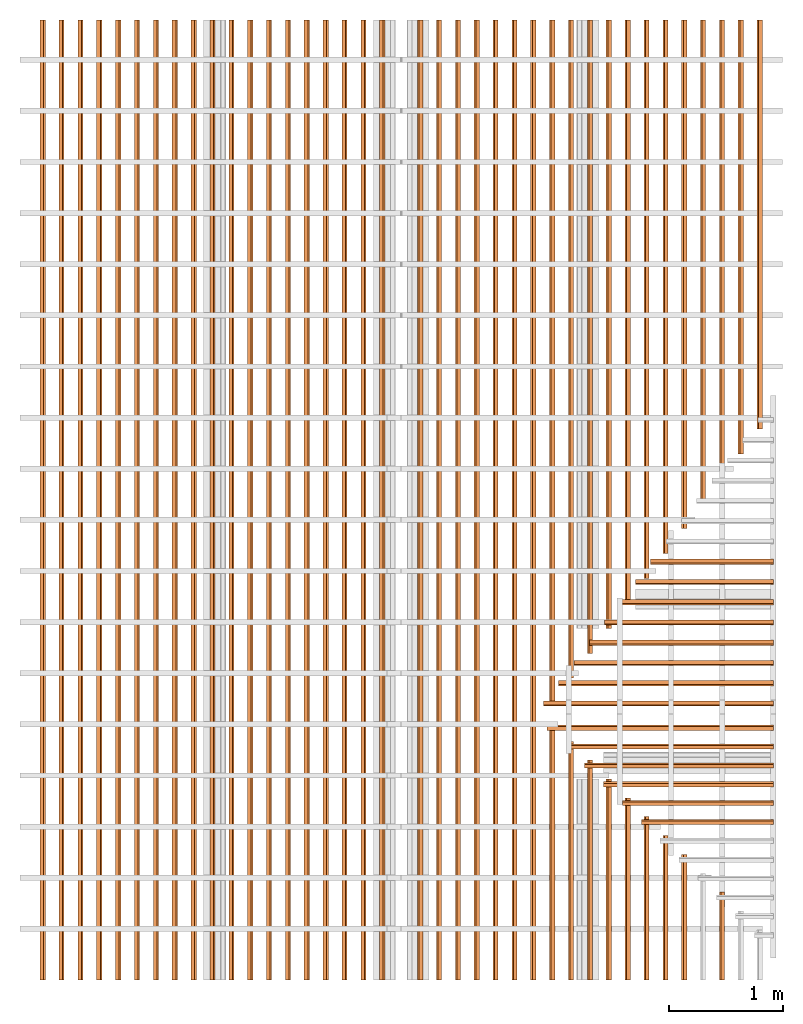
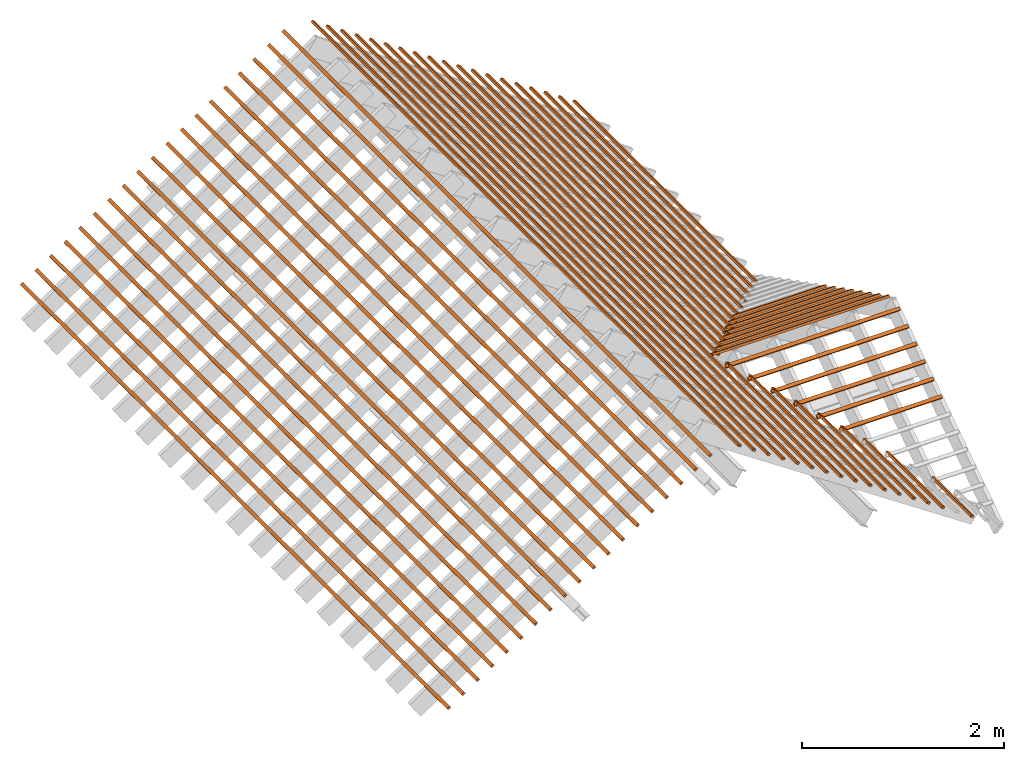
# One storey, part 2 of 3: 61 proxies, 5 elements without a shape of their own.
"""IFC4 building model written with IfcOpenShell, lengths in metres."""

from ifc_helpers import new_model, entity, si_unit, converted_unit, frame, frame_2d, origin_with_axes, origin_2d_with_axis, place, context, subcontext, project, library, spatial, rectangle, extrude, material, material_profile, profile_set, profile_usage, type_object, element, aggregate, save


model = new_model("IFC4")

# Units and contexts
model_context = context("Model", 3, precision=1e-05, world=origin_with_axes())
plan_context = context("Plan", 2, precision=1e-05, world=origin_2d_with_axis())
body_context = subcontext(model_context, "Body", "Model", "MODEL_VIEW")
ifc_project = project(units=[si_unit("LENGTHUNIT", "METRE"), converted_unit("PLANEANGLEUNIT", "degree", entity("IfcReal", 0.0174532925199433), si_unit("PLANEANGLEUNIT", "RADIAN"), dimensions=[0, 0, 0, 0, 0, 0, 0]), si_unit("AREAUNIT", "SQUARE_METRE"), si_unit("VOLUMEUNIT", "CUBIC_METRE")], contexts=[model_context, plan_context])
project_library_1 = library(declared=ifc_project)
project_library_2 = library(declared=ifc_project)
project_library_3 = library(declared=ifc_project)

# Site, building, storey
site_placement = place(None, frame((-0.0250487327575684, 0.0, 0.0), z_axis=(0.0, 0.0, 1.0), x_axis=(1.0, 0.0, 0.0)))
site = spatial("IfcSite", under=ifc_project, at=site_placement)
building_placement = place(site_placement, origin_with_axes())
building = spatial("IfcBuilding", under=site, at=building_placement, Name="Building")
storey_placement = place(building_placement, frame((0.0250487327575684, 0.0, 0.0), z_axis=(0.0, 0.0, 1.0), x_axis=(1.0, 0.0, 0.0)))
storey = spatial("IfcBuildingStorey", under=building, at=storey_placement, Name="Roof framing", CompositionType="ELEMENT", Elevation=0.0)

# Assemblies, proxies
assembly_1_placement = place(storey_placement, origin_with_axes())
assembly_1 = element("IfcElementAssembly", 1, at=assembly_1_placement, inside=storey, Name="battens")
assembly_2_placement = place(assembly_1_placement, frame((1.27500009536743, -6.61744490042422e-24, 2.40000009536743), z_axis=(0.557621447781006, -6.78052809385821e-09, 0.830095368602075), x_axis=(1.21597333116231e-08, 1.0, -6.86638795477696e-25)))
assembly_2 = element("IfcElementAssembly", 2, at=assembly_2_placement, Name="battens")
ifc_material = material(Name="Timber")
ifc_material_profile = material_profile(ifc_material, rectangle(XDim=0.038, YDim=0.026, at=frame_2d((0.0, 0.083), x_axis=(1.0, 0.0))))
ifc_profile_set = profile_set([ifc_material_profile])
ifc_profile_usage_1 = profile_usage(ifc_profile_set)
building_element_proxy_type = type_object("IfcBuildingElementProxyType", Name="batten", PredefinedType="NOTDEFINED", material=ifc_profile_set)
proxy_1_placement = place(assembly_2_placement, frame((0.773057153131958, 0.6, 0.0), z_axis=(-1.0, 0.0, 0.0), x_axis=(0.0, -1.0, 0.0)))
proxy_1 = element("IfcBuildingElementProxy", 3, at=proxy_1_placement, type_object=building_element_proxy_type, material=ifc_profile_usage_1, Name="batten", context=body_context, shape_type="SweptSolid", body=[
    extrude(rectangle(XDim=0.038, YDim=0.026, at=frame_2d((0.0, 0.083), x_axis=(1.0, 0.0))), origin_with_axes(), (0.0, 0.0, 1.0), 0.77305719295508),
])
ifc_profile_usage_2 = profile_usage(ifc_profile_set)
proxy_2_placement = place(assembly_2_placement, frame((1.10509527265061, 1.0, 0.0), z_axis=(-1.0, 0.0, 0.0), x_axis=(0.0, -1.0, 0.0)))
proxy_2 = element("IfcBuildingElementProxy", 4, at=proxy_2_placement, type_object=building_element_proxy_type, material=ifc_profile_usage_2, Name="batten", context=body_context, shape_type="SweptSolid", body=[
    extrude(rectangle(XDim=0.038, YDim=0.026, at=frame_2d((0.0, 0.083), x_axis=(1.0, 0.0))), origin_with_axes(), (0.0, 0.0, 1.0), 1.10509531247373),
])
ifc_profile_usage_3 = profile_usage(ifc_profile_set)
proxy_3_placement = place(assembly_2_placement, frame((1.27111433240993, 1.2, 0.0), z_axis=(-1.0, 0.0, 0.0), x_axis=(0.0, -1.0, 0.0)))
proxy_3 = element("IfcBuildingElementProxy", 5, at=proxy_3_placement, type_object=building_element_proxy_type, material=ifc_profile_usage_3, Name="batten", context=body_context, shape_type="SweptSolid", body=[
    extrude(rectangle(XDim=0.038, YDim=0.026, at=frame_2d((0.0, 0.083), x_axis=(1.0, 0.0))), origin_with_axes(), (0.0, 0.0, 1.0), 1.27111437223306),
])
ifc_profile_usage_4 = profile_usage(ifc_profile_set)
proxy_4_placement = place(assembly_2_placement, frame((1.43713339216926, 1.4, 0.0), z_axis=(-1.0, 0.0, 0.0), x_axis=(0.0, -1.0, 0.0)))
proxy_4 = element("IfcBuildingElementProxy", 6, at=proxy_4_placement, type_object=building_element_proxy_type, material=ifc_profile_usage_4, Name="batten", context=body_context, shape_type="SweptSolid", body=[
    extrude(rectangle(XDim=0.038, YDim=0.026, at=frame_2d((0.0, 0.083), x_axis=(1.0, 0.0))), origin_with_axes(), (0.0, 0.0, 1.0), 1.43713343199238),
])
ifc_profile_usage_5 = profile_usage(ifc_profile_set)
proxy_5_placement = place(assembly_2_placement, frame((1.60315245192858, 1.6, 0.0), z_axis=(-1.0, 0.0, 0.0), x_axis=(0.0, -1.0, 0.0)))
proxy_5 = element("IfcBuildingElementProxy", 7, at=proxy_5_placement, type_object=building_element_proxy_type, material=ifc_profile_usage_5, Name="batten", context=body_context, shape_type="SweptSolid", body=[
    extrude(rectangle(XDim=0.038, YDim=0.026, at=frame_2d((0.0, 0.083), x_axis=(1.0, 0.0))), origin_with_axes(), (0.0, 0.0, 1.0), 1.60315249175171),
])
ifc_profile_usage_6 = profile_usage(ifc_profile_set)
proxy_6_placement = place(assembly_2_placement, frame((1.76917151168791, 1.8, 0.0), z_axis=(-1.0, 0.0, 0.0), x_axis=(0.0, -1.0, 0.0)))
proxy_6 = element("IfcBuildingElementProxy", 8, at=proxy_6_placement, type_object=building_element_proxy_type, material=ifc_profile_usage_6, Name="batten", context=body_context, shape_type="SweptSolid", body=[
    extrude(rectangle(XDim=0.038, YDim=0.026, at=frame_2d((0.0, 0.083), x_axis=(1.0, 0.0))), origin_with_axes(), (0.0, 0.0, 1.0), 1.76917155151103),
])
ifc_profile_usage_7 = profile_usage(ifc_profile_set)
proxy_7_placement = place(assembly_2_placement, frame((1.93519057144723, 2.0, 0.0), z_axis=(-1.0, -1.1474043106238e-16, 0.0), x_axis=(1.1474043106238e-16, -1.0, 0.0)))
proxy_7 = element("IfcBuildingElementProxy", 9, at=proxy_7_placement, type_object=building_element_proxy_type, material=ifc_profile_usage_7, Name="batten", context=body_context, shape_type="SweptSolid", body=[
    extrude(rectangle(XDim=0.038, YDim=0.026, at=frame_2d((0.0, 0.083), x_axis=(1.0, 0.0))), origin_with_axes(), (0.0, 0.0, 1.0), 1.93519061127036),
])
ifc_profile_usage_8 = profile_usage(ifc_profile_set)
proxy_8_placement = place(assembly_2_placement, frame((2.10120963120656, 2.2, 0.0), z_axis=(-1.0, 2.11349307959562e-16, 0.0), x_axis=(-2.11349307959562e-16, -1.0, 0.0)))
proxy_8 = element("IfcBuildingElementProxy", 10, at=proxy_8_placement, type_object=building_element_proxy_type, material=ifc_profile_usage_8, Name="batten", context=body_context, shape_type="SweptSolid", body=[
    extrude(rectangle(XDim=0.038, YDim=0.026, at=frame_2d((0.0, 0.083), x_axis=(1.0, 0.0))), origin_with_axes(), (0.0, 0.0, 1.0), 2.10120967102968),
])
ifc_profile_usage_9 = profile_usage(ifc_profile_set)
proxy_9_placement = place(assembly_2_placement, frame((2.26722869096588, 2.4, 0.0), z_axis=(-1.0, 1.95873139670172e-16, 0.0), x_axis=(-1.95873139670172e-16, -1.0, 0.0)))
proxy_9 = element("IfcBuildingElementProxy", 11, at=proxy_9_placement, type_object=building_element_proxy_type, material=ifc_profile_usage_9, Name="batten", context=body_context, shape_type="SweptSolid", body=[
    extrude(rectangle(XDim=0.038, YDim=0.026, at=frame_2d((0.0, 0.083), x_axis=(1.0, 0.0))), origin_with_axes(), (0.0, 0.0, 1.0), 2.26722873078901),
])
ifc_profile_usage_10 = profile_usage(ifc_profile_set)
proxy_10_placement = place(assembly_2_placement, frame((8.44999980926514, 2.6, 0.0), z_axis=(-1.0, 0.0, 0.0), x_axis=(0.0, -1.0, 0.0)))
proxy_10 = element("IfcBuildingElementProxy", 12, at=proxy_10_placement, type_object=building_element_proxy_type, material=ifc_profile_usage_10, Name="batten", context=body_context, shape_type="SweptSolid", body=[
    extrude(rectangle(XDim=0.038, YDim=0.026, at=frame_2d((0.0, 0.083), x_axis=(1.0, 0.0))), origin_with_axes(), (0.0, 0.0, 1.0), 8.44999984908826),
])
ifc_profile_usage_11 = profile_usage(ifc_profile_set)
proxy_11_placement = place(assembly_2_placement, frame((8.44999980926514, 2.4, 0.0), z_axis=(-1.0, 0.0, 0.0), x_axis=(0.0, -1.0, 0.0)))
proxy_11 = element("IfcBuildingElementProxy", 13, at=proxy_11_placement, type_object=building_element_proxy_type, material=ifc_profile_usage_11, Name="batten", context=body_context, shape_type="SweptSolid", body=[
    extrude(rectangle(XDim=0.038, YDim=0.026, at=frame_2d((0.0, 0.083), x_axis=(1.0, 0.0))), origin_with_axes(), (0.0, 0.0, 1.0), 6.01336081066731),
])
ifc_profile_usage_12 = profile_usage(ifc_profile_set)
proxy_12_placement = place(assembly_2_placement, frame((8.44999980926514, 2.8, 0.0), z_axis=(-1.0, 0.0, 0.0), x_axis=(0.0, -1.0, 0.0)))
proxy_12 = element("IfcBuildingElementProxy", 14, at=proxy_12_placement, type_object=building_element_proxy_type, material=ifc_profile_usage_12, Name="batten", context=body_context, shape_type="SweptSolid", body=[
    extrude(rectangle(XDim=0.038, YDim=0.026, at=frame_2d((0.0, 0.083), x_axis=(1.0, 0.0))), origin_with_axes(), (0.0, 0.0, 1.0), 8.44999984908826),
])
ifc_profile_usage_13 = profile_usage(ifc_profile_set)
proxy_13_placement = place(assembly_2_placement, frame((8.44999980926514, 2.2, 0.0), z_axis=(-1.0, 0.0, 0.0), x_axis=(0.0, -1.0, 0.0)))
proxy_13 = element("IfcBuildingElementProxy", 15, at=proxy_13_placement, type_object=building_element_proxy_type, material=ifc_profile_usage_13, Name="batten", context=body_context, shape_type="SweptSolid", body=[
    extrude(rectangle(XDim=0.038, YDim=0.026, at=frame_2d((0.0, 0.083), x_axis=(1.0, 0.0))), origin_with_axes(), (0.0, 0.0, 1.0), 5.79391408130251),
])
ifc_profile_usage_14 = profile_usage(ifc_profile_set)
proxy_14_placement = place(assembly_2_placement, frame((8.44999980926514, 3.0, 0.0), z_axis=(-1.0, 0.0, 0.0), x_axis=(0.0, -1.0, 0.0)))
proxy_14 = element("IfcBuildingElementProxy", 16, at=proxy_14_placement, type_object=building_element_proxy_type, material=ifc_profile_usage_14, Name="batten", context=body_context, shape_type="SweptSolid", body=[
    extrude(rectangle(XDim=0.038, YDim=0.026, at=frame_2d((0.0, 0.083), x_axis=(1.0, 0.0))), origin_with_axes(), (0.0, 0.0, 1.0), 8.44999984908826),
])
ifc_profile_usage_15 = profile_usage(ifc_profile_set)
proxy_15_placement = place(assembly_2_placement, frame((8.44999980926514, 2.0, 0.0), z_axis=(-1.0, 0.0, 0.0), x_axis=(0.0, -1.0, 0.0)))
proxy_15 = element("IfcBuildingElementProxy", 17, at=proxy_15_placement, type_object=building_element_proxy_type, material=ifc_profile_usage_15, Name="batten", context=body_context, shape_type="SweptSolid", body=[
    extrude(rectangle(XDim=0.038, YDim=0.026, at=frame_2d((0.0, 0.083), x_axis=(1.0, 0.0))), origin_with_axes(), (0.0, 0.0, 1.0), 5.57446735193771),
])
ifc_profile_usage_16 = profile_usage(ifc_profile_set)
proxy_16_placement = place(assembly_2_placement, frame((8.44999980926514, 3.2, 0.0), z_axis=(-1.0, 0.0, 0.0), x_axis=(0.0, -1.0, 0.0)))
proxy_16 = element("IfcBuildingElementProxy", 18, at=proxy_16_placement, type_object=building_element_proxy_type, material=ifc_profile_usage_16, Name="batten", context=body_context, shape_type="SweptSolid", body=[
    extrude(rectangle(XDim=0.038, YDim=0.026, at=frame_2d((0.0, 0.083), x_axis=(1.0, 0.0))), origin_with_axes(), (0.0, 0.0, 1.0), 8.44999984908826),
])
ifc_profile_usage_17 = profile_usage(ifc_profile_set)
proxy_17_placement = place(assembly_2_placement, frame((8.44999980926514, 1.8, 0.0), z_axis=(-1.0, 0.0, 0.0), x_axis=(0.0, -1.0, 0.0)))
proxy_17 = element("IfcBuildingElementProxy", 19, at=proxy_17_placement, type_object=building_element_proxy_type, material=ifc_profile_usage_17, Name="batten", context=body_context, shape_type="SweptSolid", body=[
    extrude(rectangle(XDim=0.038, YDim=0.026, at=frame_2d((0.0, 0.083), x_axis=(1.0, 0.0))), origin_with_axes(), (0.0, 0.0, 1.0), 5.35502062257291),
])
ifc_profile_usage_18 = profile_usage(ifc_profile_set)
proxy_18_placement = place(assembly_2_placement, frame((8.44999980926514, 3.4, 0.0), z_axis=(-1.0, 0.0, 0.0), x_axis=(0.0, -1.0, 0.0)))
proxy_18 = element("IfcBuildingElementProxy", 20, at=proxy_18_placement, type_object=building_element_proxy_type, material=ifc_profile_usage_18, Name="batten", context=body_context, shape_type="SweptSolid", body=[
    extrude(rectangle(XDim=0.038, YDim=0.026, at=frame_2d((0.0, 0.083), x_axis=(1.0, 0.0))), origin_with_axes(), (0.0, 0.0, 1.0), 8.44999984908826),
])
ifc_profile_usage_19 = profile_usage(ifc_profile_set)
proxy_19_placement = place(assembly_2_placement, frame((8.44999980926514, 1.6, 0.0), z_axis=(-1.0, 0.0, 0.0), x_axis=(0.0, -1.0, 0.0)))
proxy_19 = element("IfcBuildingElementProxy", 21, at=proxy_19_placement, type_object=building_element_proxy_type, material=ifc_profile_usage_19, Name="batten", context=body_context, shape_type="SweptSolid", body=[
    extrude(rectangle(XDim=0.038, YDim=0.026, at=frame_2d((0.0, 0.083), x_axis=(1.0, 0.0))), origin_with_axes(), (0.0, 0.0, 1.0), 5.13557389320811),
])
ifc_profile_usage_20 = profile_usage(ifc_profile_set)
proxy_20_placement = place(assembly_2_placement, frame((8.44999980926514, 3.6, 0.0), z_axis=(-1.0, 0.0, 0.0), x_axis=(0.0, -1.0, 0.0)))
proxy_20 = element("IfcBuildingElementProxy", 22, at=proxy_20_placement, type_object=building_element_proxy_type, material=ifc_profile_usage_20, Name="batten", context=body_context, shape_type="SweptSolid", body=[
    extrude(rectangle(XDim=0.038, YDim=0.026, at=frame_2d((0.0, 0.083), x_axis=(1.0, 0.0))), origin_with_axes(), (0.0, 0.0, 1.0), 8.44999984908826),
])
ifc_profile_usage_21 = profile_usage(ifc_profile_set)
proxy_21_placement = place(assembly_2_placement, frame((8.44999980926514, 1.4, 0.0), z_axis=(-1.0, 0.0, 0.0), x_axis=(0.0, -1.0, 0.0)))
proxy_21 = element("IfcBuildingElementProxy", 23, at=proxy_21_placement, type_object=building_element_proxy_type, material=ifc_profile_usage_21, Name="batten", context=body_context, shape_type="SweptSolid", body=[
    extrude(rectangle(XDim=0.038, YDim=0.026, at=frame_2d((0.0, 0.083), x_axis=(1.0, 0.0))), origin_with_axes(), (0.0, 0.0, 1.0), 4.91612716384331),
])
ifc_profile_usage_22 = profile_usage(ifc_profile_set)
proxy_22_placement = place(assembly_2_placement, frame((8.44999980926514, 3.8, 0.0), z_axis=(-1.0, 0.0, 0.0), x_axis=(0.0, -1.0, 0.0)))
proxy_22 = element("IfcBuildingElementProxy", 24, at=proxy_22_placement, type_object=building_element_proxy_type, material=ifc_profile_usage_22, Name="batten", context=body_context, shape_type="SweptSolid", body=[
    extrude(rectangle(XDim=0.038, YDim=0.026, at=frame_2d((0.0, 0.083), x_axis=(1.0, 0.0))), origin_with_axes(), (0.0, 0.0, 1.0), 8.44999984908826),
])
ifc_profile_usage_23 = profile_usage(ifc_profile_set)
proxy_23_placement = place(assembly_2_placement, frame((8.44999980926514, 1.2, 0.0), z_axis=(-1.0, 4.72769242069342e-17, 0.0), x_axis=(-4.72769242069342e-17, -1.0, 0.0)))
proxy_23 = element("IfcBuildingElementProxy", 25, at=proxy_23_placement, type_object=building_element_proxy_type, material=ifc_profile_usage_23, Name="batten", context=body_context, shape_type="SweptSolid", body=[
    extrude(rectangle(XDim=0.038, YDim=0.026, at=frame_2d((0.0, 0.083), x_axis=(1.0, 0.0))), origin_with_axes(), (0.0, 0.0, 1.0), 4.69668043447851),
])
ifc_profile_usage_24 = profile_usage(ifc_profile_set)
proxy_24_placement = place(assembly_2_placement, frame((8.44999980926514, 1.0, 0.0), z_axis=(-1.0, 0.0, 0.0), x_axis=(0.0, -1.0, 0.0)))
proxy_24 = element("IfcBuildingElementProxy", 26, at=proxy_24_placement, type_object=building_element_proxy_type, material=ifc_profile_usage_24, Name="batten", context=body_context, shape_type="SweptSolid", body=[
    extrude(rectangle(XDim=0.038, YDim=0.026, at=frame_2d((0.0, 0.083), x_axis=(1.0, 0.0))), origin_with_axes(), (0.0, 0.0, 1.0), 4.47723370511371),
])
ifc_profile_usage_25 = profile_usage(ifc_profile_set)
proxy_25_placement = place(assembly_2_placement, frame((8.44999980926514, 0.8, 0.0), z_axis=(-1.0, 2.60751190923514e-17, 0.0), x_axis=(-2.60751190923514e-17, -1.0, 0.0)))
proxy_25 = element("IfcBuildingElementProxy", 27, at=proxy_25_placement, type_object=building_element_proxy_type, material=ifc_profile_usage_25, Name="batten", context=body_context, shape_type="SweptSolid", body=[
    extrude(rectangle(XDim=0.038, YDim=0.026, at=frame_2d((0.0, 0.083), x_axis=(1.0, 0.0))), origin_with_axes(), (0.0, 0.0, 1.0), 4.25778697574891),
])
ifc_profile_usage_26 = profile_usage(ifc_profile_set)
proxy_26_placement = place(assembly_2_placement, frame((8.44999980926514, 0.6, 0.0), z_axis=(-1.0, -5.4984125006269e-17, 0.0), x_axis=(5.4984125006269e-17, -1.0, 0.0)))
proxy_26 = element("IfcBuildingElementProxy", 28, at=proxy_26_placement, type_object=building_element_proxy_type, material=ifc_profile_usage_26, Name="batten", context=body_context, shape_type="SweptSolid", body=[
    extrude(rectangle(XDim=0.038, YDim=0.026, at=frame_2d((0.0, 0.083), x_axis=(1.0, 0.0))), origin_with_axes(), (0.0, 0.0, 1.0), 4.03834024638411),
])
ifc_profile_usage_27 = profile_usage(ifc_profile_set)
proxy_27_placement = place(assembly_2_placement, frame((8.44999980926514, 0.4, 0.0), z_axis=(-1.0, -1.45359253888244e-17, 0.0), x_axis=(1.45359253888244e-17, -1.0, 0.0)))
proxy_27 = element("IfcBuildingElementProxy", 29, at=proxy_27_placement, type_object=building_element_proxy_type, material=ifc_profile_usage_27, Name="batten", context=body_context, shape_type="SweptSolid", body=[
    extrude(rectangle(XDim=0.038, YDim=0.026, at=frame_2d((0.0, 0.083), x_axis=(1.0, 0.0))), origin_with_axes(), (0.0, 0.0, 1.0), 3.81889351701931),
])
ifc_profile_usage_28 = profile_usage(ifc_profile_set)
proxy_28_placement = place(assembly_2_placement, frame((8.44999980926514, 0.2, 0.0), z_axis=(-1.0, -3.85553353793502e-17, 0.0), x_axis=(3.85553353793502e-17, -1.0, 0.0)))
proxy_28 = element("IfcBuildingElementProxy", 30, at=proxy_28_placement, type_object=building_element_proxy_type, material=ifc_profile_usage_28, Name="batten", context=body_context, shape_type="SweptSolid", body=[
    extrude(rectangle(XDim=0.038, YDim=0.026, at=frame_2d((0.0, 0.083), x_axis=(1.0, 0.0))), origin_with_axes(), (0.0, 0.0, 1.0), 3.59944678765451),
])
aggregate(assembly_2, [proxy_1, proxy_2, proxy_3, proxy_4, proxy_5, proxy_6, proxy_7, proxy_8, proxy_9, proxy_10, proxy_11, proxy_12, proxy_13, proxy_14, proxy_15, proxy_16, proxy_17, proxy_18, proxy_19, proxy_20, proxy_21, proxy_22, proxy_23, proxy_24, proxy_25, proxy_26, proxy_27, proxy_28])
assembly_3_placement = place(assembly_1_placement, frame((-5.27499914169312, 0.0, 2.40000009536743), z_axis=(-0.557621451915285, 0.0, 0.830095365824849), x_axis=(0.0, -1.0, 0.0)))
assembly_3 = element("IfcElementAssembly", 31, at=assembly_3_placement, Name="battens")
ifc_profile_usage_29 = profile_usage(ifc_profile_set)
proxy_29_placement = place(assembly_3_placement, frame((0.0, 0.2, 0.0), z_axis=(-1.0, 0.0, 0.0), x_axis=(0.0, -1.0, 0.0)))
proxy_29 = element("IfcBuildingElementProxy", 32, at=proxy_29_placement, type_object=building_element_proxy_type, material=ifc_profile_usage_29, Name="batten", context=body_context, shape_type="SweptSolid", body=[
    extrude(rectangle(XDim=0.038, YDim=0.026, at=frame_2d((0.0, 0.083), x_axis=(1.0, 0.0))), origin_with_axes(), (0.0, 0.0, 1.0), 8.44999980926514),
])
ifc_profile_usage_30 = profile_usage(ifc_profile_set)
proxy_30_placement = place(assembly_3_placement, frame((0.0, 0.4, 0.0), z_axis=(-1.0, 0.0, 0.0), x_axis=(0.0, -1.0, 0.0)))
proxy_30 = element("IfcBuildingElementProxy", 33, at=proxy_30_placement, type_object=building_element_proxy_type, material=ifc_profile_usage_30, Name="batten", context=body_context, shape_type="SweptSolid", body=[
    extrude(rectangle(XDim=0.038, YDim=0.026, at=frame_2d((0.0, 0.083), x_axis=(1.0, 0.0))), origin_with_axes(), (0.0, 0.0, 1.0), 8.44999980926514),
])
ifc_profile_usage_31 = profile_usage(ifc_profile_set)
proxy_31_placement = place(assembly_3_placement, frame((0.0, 0.6, 0.0), z_axis=(-1.0, 0.0, 0.0), x_axis=(0.0, -1.0, 0.0)))
proxy_31 = element("IfcBuildingElementProxy", 34, at=proxy_31_placement, type_object=building_element_proxy_type, material=ifc_profile_usage_31, Name="batten", context=body_context, shape_type="SweptSolid", body=[
    extrude(rectangle(XDim=0.038, YDim=0.026, at=frame_2d((0.0, 0.083), x_axis=(1.0, 0.0))), origin_with_axes(), (0.0, 0.0, 1.0), 8.44999980926514),
])
ifc_profile_usage_32 = profile_usage(ifc_profile_set)
proxy_32_placement = place(assembly_3_placement, frame((0.0, 0.8, 0.0), z_axis=(-1.0, 0.0, 0.0), x_axis=(0.0, -1.0, 0.0)))
proxy_32 = element("IfcBuildingElementProxy", 35, at=proxy_32_placement, type_object=building_element_proxy_type, material=ifc_profile_usage_32, Name="batten", context=body_context, shape_type="SweptSolid", body=[
    extrude(rectangle(XDim=0.038, YDim=0.026, at=frame_2d((0.0, 0.083), x_axis=(1.0, 0.0))), origin_with_axes(), (0.0, 0.0, 1.0), 8.44999980926514),
])
ifc_profile_usage_33 = profile_usage(ifc_profile_set)
proxy_33_placement = place(assembly_3_placement, frame((0.0, 1.0, 0.0), z_axis=(-1.0, 0.0, 0.0), x_axis=(0.0, -1.0, 0.0)))
proxy_33 = element("IfcBuildingElementProxy", 36, at=proxy_33_placement, type_object=building_element_proxy_type, material=ifc_profile_usage_33, Name="batten", context=body_context, shape_type="SweptSolid", body=[
    extrude(rectangle(XDim=0.038, YDim=0.026, at=frame_2d((0.0, 0.083), x_axis=(1.0, 0.0))), origin_with_axes(), (0.0, 0.0, 1.0), 8.44999980926514),
])
ifc_profile_usage_34 = profile_usage(ifc_profile_set)
proxy_34_placement = place(assembly_3_placement, frame((0.0, 1.2, 0.0), z_axis=(-1.0, 0.0, 0.0), x_axis=(0.0, -1.0, 0.0)))
proxy_34 = element("IfcBuildingElementProxy", 37, at=proxy_34_placement, type_object=building_element_proxy_type, material=ifc_profile_usage_34, Name="batten", context=body_context, shape_type="SweptSolid", body=[
    extrude(rectangle(XDim=0.038, YDim=0.026, at=frame_2d((0.0, 0.083), x_axis=(1.0, 0.0))), origin_with_axes(), (0.0, 0.0, 1.0), 8.44999980926514),
])
ifc_profile_usage_35 = profile_usage(ifc_profile_set)
proxy_35_placement = place(assembly_3_placement, frame((0.0, 1.4, 0.0), z_axis=(-1.0, 0.0, 0.0), x_axis=(0.0, -1.0, 0.0)))
proxy_35 = element("IfcBuildingElementProxy", 38, at=proxy_35_placement, type_object=building_element_proxy_type, material=ifc_profile_usage_35, Name="batten", context=body_context, shape_type="SweptSolid", body=[
    extrude(rectangle(XDim=0.038, YDim=0.026, at=frame_2d((0.0, 0.083), x_axis=(1.0, 0.0))), origin_with_axes(), (0.0, 0.0, 1.0), 8.44999980926514),
])
ifc_profile_usage_36 = profile_usage(ifc_profile_set)
proxy_36_placement = place(assembly_3_placement, frame((0.0, 1.6, 0.0), z_axis=(-1.0, 0.0, 0.0), x_axis=(0.0, -1.0, 0.0)))
proxy_36 = element("IfcBuildingElementProxy", 39, at=proxy_36_placement, type_object=building_element_proxy_type, material=ifc_profile_usage_36, Name="batten", context=body_context, shape_type="SweptSolid", body=[
    extrude(rectangle(XDim=0.038, YDim=0.026, at=frame_2d((0.0, 0.083), x_axis=(1.0, 0.0))), origin_with_axes(), (0.0, 0.0, 1.0), 8.44999980926514),
])
ifc_profile_usage_37 = profile_usage(ifc_profile_set)
proxy_37_placement = place(assembly_3_placement, frame((0.0, 1.8, 0.0), z_axis=(-1.0, 0.0, 0.0), x_axis=(0.0, -1.0, 0.0)))
proxy_37 = element("IfcBuildingElementProxy", 40, at=proxy_37_placement, type_object=building_element_proxy_type, material=ifc_profile_usage_37, Name="batten", context=body_context, shape_type="SweptSolid", body=[
    extrude(rectangle(XDim=0.038, YDim=0.026, at=frame_2d((0.0, 0.083), x_axis=(1.0, 0.0))), origin_with_axes(), (0.0, 0.0, 1.0), 8.44999980926514),
])
ifc_profile_usage_38 = profile_usage(ifc_profile_set)
proxy_38_placement = place(assembly_3_placement, frame((0.0, 2.0, 0.0), z_axis=(-1.0, 0.0, 0.0), x_axis=(0.0, -1.0, 0.0)))
proxy_38 = element("IfcBuildingElementProxy", 41, at=proxy_38_placement, type_object=building_element_proxy_type, material=ifc_profile_usage_38, Name="batten", context=body_context, shape_type="SweptSolid", body=[
    extrude(rectangle(XDim=0.038, YDim=0.026, at=frame_2d((0.0, 0.083), x_axis=(1.0, 0.0))), origin_with_axes(), (0.0, 0.0, 1.0), 8.44999980926514),
])
ifc_profile_usage_39 = profile_usage(ifc_profile_set)
proxy_39_placement = place(assembly_3_placement, frame((0.0, 2.2, 0.0), z_axis=(-1.0, 0.0, 0.0), x_axis=(0.0, -1.0, 0.0)))
proxy_39 = element("IfcBuildingElementProxy", 42, at=proxy_39_placement, type_object=building_element_proxy_type, material=ifc_profile_usage_39, Name="batten", context=body_context, shape_type="SweptSolid", body=[
    extrude(rectangle(XDim=0.038, YDim=0.026, at=frame_2d((0.0, 0.083), x_axis=(1.0, 0.0))), origin_with_axes(), (0.0, 0.0, 1.0), 8.44999980926514),
])
ifc_profile_usage_40 = profile_usage(ifc_profile_set)
proxy_40_placement = place(assembly_3_placement, frame((0.0, 2.4, 0.0), z_axis=(-1.0, 0.0, 0.0), x_axis=(0.0, -1.0, 0.0)))
proxy_40 = element("IfcBuildingElementProxy", 43, at=proxy_40_placement, type_object=building_element_proxy_type, material=ifc_profile_usage_40, Name="batten", context=body_context, shape_type="SweptSolid", body=[
    extrude(rectangle(XDim=0.038, YDim=0.026, at=frame_2d((0.0, 0.083), x_axis=(1.0, 0.0))), origin_with_axes(), (0.0, 0.0, 1.0), 8.44999980926514),
])
ifc_profile_usage_41 = profile_usage(ifc_profile_set)
proxy_41_placement = place(assembly_3_placement, frame((0.0, 2.6, 0.0), z_axis=(-1.0, 0.0, 0.0), x_axis=(0.0, -1.0, 0.0)))
proxy_41 = element("IfcBuildingElementProxy", 44, at=proxy_41_placement, type_object=building_element_proxy_type, material=ifc_profile_usage_41, Name="batten", context=body_context, shape_type="SweptSolid", body=[
    extrude(rectangle(XDim=0.038, YDim=0.026, at=frame_2d((0.0, 0.083), x_axis=(1.0, 0.0))), origin_with_axes(), (0.0, 0.0, 1.0), 8.44999980926514),
])
ifc_profile_usage_42 = profile_usage(ifc_profile_set)
proxy_42_placement = place(assembly_3_placement, frame((0.0, 2.8, 0.0), z_axis=(-1.0, 0.0, 0.0), x_axis=(0.0, -1.0, 0.0)))
proxy_42 = element("IfcBuildingElementProxy", 45, at=proxy_42_placement, type_object=building_element_proxy_type, material=ifc_profile_usage_42, Name="batten", context=body_context, shape_type="SweptSolid", body=[
    extrude(rectangle(XDim=0.038, YDim=0.026, at=frame_2d((0.0, 0.083), x_axis=(1.0, 0.0))), origin_with_axes(), (0.0, 0.0, 1.0), 8.44999980926514),
])
ifc_profile_usage_43 = profile_usage(ifc_profile_set)
proxy_43_placement = place(assembly_3_placement, frame((0.0, 3.0, 0.0), z_axis=(-1.0, 0.0, 0.0), x_axis=(0.0, -1.0, 0.0)))
proxy_43 = element("IfcBuildingElementProxy", 46, at=proxy_43_placement, type_object=building_element_proxy_type, material=ifc_profile_usage_43, Name="batten", context=body_context, shape_type="SweptSolid", body=[
    extrude(rectangle(XDim=0.038, YDim=0.026, at=frame_2d((0.0, 0.083), x_axis=(1.0, 0.0))), origin_with_axes(), (0.0, 0.0, 1.0), 8.44999980926514),
])
ifc_profile_usage_44 = profile_usage(ifc_profile_set)
proxy_44_placement = place(assembly_3_placement, frame((0.0, 3.2, 0.0), z_axis=(-1.0, 0.0, 0.0), x_axis=(0.0, -1.0, 0.0)))
proxy_44 = element("IfcBuildingElementProxy", 47, at=proxy_44_placement, type_object=building_element_proxy_type, material=ifc_profile_usage_44, Name="batten", context=body_context, shape_type="SweptSolid", body=[
    extrude(rectangle(XDim=0.038, YDim=0.026, at=frame_2d((0.0, 0.083), x_axis=(1.0, 0.0))), origin_with_axes(), (0.0, 0.0, 1.0), 8.44999980926514),
])
ifc_profile_usage_45 = profile_usage(ifc_profile_set)
proxy_45_placement = place(assembly_3_placement, frame((0.0, 3.4, 0.0), z_axis=(-1.0, 0.0, 0.0), x_axis=(0.0, -1.0, 0.0)))
proxy_45 = element("IfcBuildingElementProxy", 48, at=proxy_45_placement, type_object=building_element_proxy_type, material=ifc_profile_usage_45, Name="batten", context=body_context, shape_type="SweptSolid", body=[
    extrude(rectangle(XDim=0.038, YDim=0.026, at=frame_2d((0.0, 0.083), x_axis=(1.0, 0.0))), origin_with_axes(), (0.0, 0.0, 1.0), 8.44999980926514),
])
ifc_profile_usage_46 = profile_usage(ifc_profile_set)
proxy_46_placement = place(assembly_3_placement, frame((0.0, 3.6, 0.0), z_axis=(-1.0, 0.0, 0.0), x_axis=(0.0, -1.0, 0.0)))
proxy_46 = element("IfcBuildingElementProxy", 49, at=proxy_46_placement, type_object=building_element_proxy_type, material=ifc_profile_usage_46, Name="batten", context=body_context, shape_type="SweptSolid", body=[
    extrude(rectangle(XDim=0.038, YDim=0.026, at=frame_2d((0.0, 0.083), x_axis=(1.0, 0.0))), origin_with_axes(), (0.0, 0.0, 1.0), 8.44999980926514),
])
ifc_profile_usage_47 = profile_usage(ifc_profile_set)
proxy_47_placement = place(assembly_3_placement, frame((0.0, 3.8, 0.0), z_axis=(-1.0, 0.0, 0.0), x_axis=(0.0, -1.0, 0.0)))
proxy_47 = element("IfcBuildingElementProxy", 50, at=proxy_47_placement, type_object=building_element_proxy_type, material=ifc_profile_usage_47, Name="batten", context=body_context, shape_type="SweptSolid", body=[
    extrude(rectangle(XDim=0.038, YDim=0.026, at=frame_2d((0.0, 0.083), x_axis=(1.0, 0.0))), origin_with_axes(), (0.0, 0.0, 1.0), 8.44999980926514),
])
aggregate(assembly_3, [proxy_29, proxy_30, proxy_31, proxy_32, proxy_33, proxy_34, proxy_35, proxy_36, proxy_37, proxy_38, proxy_39, proxy_40, proxy_41, proxy_42, proxy_43, proxy_44, proxy_45, proxy_46, proxy_47])
assembly_4_placement = place(assembly_1_placement, frame((1.27500009536743, 5.06999969482422, 2.40000009536743), z_axis=(-1.8134071260532e-16, 0.453056810096847, 0.891481646936643), x_axis=(-1.0, -4.00260427751998e-16, -2.19767193434487e-32)))
assembly_4 = element("IfcElementAssembly", 51, at=assembly_4_placement, Name="battens")
ifc_profile_usage_48 = profile_usage(ifc_profile_set)
proxy_48_placement = place(assembly_4_placement, frame((1.07909907367867, 1.6, 0.0), z_axis=(-1.0, 0.0, 0.0), x_axis=(0.0, -1.0, 0.0)))
proxy_48 = element("IfcBuildingElementProxy", 52, at=proxy_48_placement, type_object=building_element_proxy_type, material=ifc_profile_usage_48, Name="batten", context=body_context, shape_type="SweptSolid", body=[
    extrude(rectangle(XDim=0.038, YDim=0.026, at=frame_2d((0.0, 0.083), x_axis=(1.0, 0.0))), origin_with_axes(), (0.0, 0.0, 1.0), 1.07910044403439),
])
ifc_profile_usage_49 = profile_usage(ifc_profile_set)
proxy_49_placement = place(assembly_4_placement, frame((1.2139864578885, 1.8, 0.0), z_axis=(-1.0, 1.82905106977505e-16, 0.0), x_axis=(-1.82905106977505e-16, -1.0, 0.0)))
proxy_49 = element("IfcBuildingElementProxy", 53, at=proxy_49_placement, type_object=building_element_proxy_type, material=ifc_profile_usage_49, Name="batten", context=body_context, shape_type="SweptSolid", body=[
    extrude(rectangle(XDim=0.038, YDim=0.026, at=frame_2d((0.0, 0.083), x_axis=(1.0, 0.0))), origin_with_axes(), (0.0, 0.0, 1.0), 1.21398799953869),
])
ifc_profile_usage_50 = profile_usage(ifc_profile_set)
proxy_50_placement = place(assembly_4_placement, frame((1.34887384209834, 2.0, 0.0), z_axis=(-1.0, 3.29229192559508e-16, 0.0), x_axis=(-3.29229192559508e-16, -1.0, 0.0)))
proxy_50 = element("IfcBuildingElementProxy", 54, at=proxy_50_placement, type_object=building_element_proxy_type, material=ifc_profile_usage_50, Name="batten", context=body_context, shape_type="SweptSolid", body=[
    extrude(rectangle(XDim=0.038, YDim=0.026, at=frame_2d((0.0, 0.083), x_axis=(1.0, 0.0))), origin_with_axes(), (0.0, 0.0, 1.0), 1.34887555504299),
])
ifc_profile_usage_51 = profile_usage(ifc_profile_set)
proxy_51_placement = place(assembly_4_placement, frame((1.48376122630817, 2.2, 0.0), z_axis=(-1.0, 2.99299265963189e-16, 0.0), x_axis=(-2.99299265963189e-16, -1.0, 0.0)))
proxy_51 = element("IfcBuildingElementProxy", 55, at=proxy_51_placement, type_object=building_element_proxy_type, material=ifc_profile_usage_51, Name="batten", context=body_context, shape_type="SweptSolid", body=[
    extrude(rectangle(XDim=0.038, YDim=0.026, at=frame_2d((0.0, 0.083), x_axis=(1.0, 0.0))), origin_with_axes(), (0.0, 0.0, 1.0), 1.48376311054729),
])
ifc_profile_usage_52 = profile_usage(ifc_profile_set)
proxy_52_placement = place(assembly_4_placement, frame((1.618648610518, 2.4, 0.0), z_axis=(-1.0, 0.0, 0.0), x_axis=(0.0, -1.0, 0.0)))
proxy_52 = element("IfcBuildingElementProxy", 56, at=proxy_52_placement, type_object=building_element_proxy_type, material=ifc_profile_usage_52, Name="batten", context=body_context, shape_type="SweptSolid", body=[
    extrude(rectangle(XDim=0.038, YDim=0.026, at=frame_2d((0.0, 0.083), x_axis=(1.0, 0.0))), origin_with_axes(), (0.0, 0.0, 1.0), 1.61865066605159),
])
ifc_profile_usage_53 = profile_usage(ifc_profile_set)
proxy_53_placement = place(assembly_4_placement, frame((1.75353599472784, 2.6, 0.0), z_axis=(-1.0, 2.53253196465954e-16, 0.0), x_axis=(-2.53253196465954e-16, -1.0, 0.0)))
proxy_53 = element("IfcBuildingElementProxy", 57, at=proxy_53_placement, type_object=building_element_proxy_type, material=ifc_profile_usage_53, Name="batten", context=body_context, shape_type="SweptSolid", body=[
    extrude(rectangle(XDim=0.038, YDim=0.026, at=frame_2d((0.0, 0.083), x_axis=(1.0, 0.0))), origin_with_axes(), (0.0, 0.0, 1.0), 1.75353841944405),
])
ifc_profile_usage_54 = profile_usage(ifc_profile_set)
proxy_54_placement = place(assembly_4_placement, frame((1.88842337893767, 2.8, 0.0), z_axis=(-1.0, 2.35163681016588e-16, 0.0), x_axis=(-2.35163681016588e-16, -1.0, 0.0)))
proxy_54 = element("IfcBuildingElementProxy", 58, at=proxy_54_placement, type_object=building_element_proxy_type, material=ifc_profile_usage_54, Name="batten", context=body_context, shape_type="SweptSolid", body=[
    extrude(rectangle(XDim=0.038, YDim=0.026, at=frame_2d((0.0, 0.083), x_axis=(1.0, 0.0))), origin_with_axes(), (0.0, 0.0, 1.0), 1.88842600154204),
])
ifc_profile_usage_55 = profile_usage(ifc_profile_set)
proxy_55_placement = place(assembly_4_placement, frame((2.0233107631475, 3.0, 0.0), z_axis=(-1.0, 0.0, 0.0), x_axis=(0.0, -1.0, 0.0)))
proxy_55 = element("IfcBuildingElementProxy", 59, at=proxy_55_placement, type_object=building_element_proxy_type, material=ifc_profile_usage_55, Name="batten", context=body_context, shape_type="SweptSolid", body=[
    extrude(rectangle(XDim=0.038, YDim=0.026, at=frame_2d((0.0, 0.083), x_axis=(1.0, 0.0))), origin_with_axes(), (0.0, 0.0, 1.0), 2.02331338575187),
])
aggregate(assembly_4, [proxy_48, proxy_49, proxy_50, proxy_51, proxy_52, proxy_53, proxy_54, proxy_55])
assembly_5_placement = place(assembly_1_placement, frame((1.27500009536743, 0.274999976158142, 2.40000009536743), z_axis=(-5.93234342970621e-17, -0.55762137886684, 0.830095414895567), x_axis=(1.0, -1.0638658513706e-16, 0.0)))
assembly_5 = element("IfcElementAssembly", 60, at=assembly_5_placement, Name="battens")
aggregate(assembly_1, [assembly_2, assembly_3, assembly_4, assembly_5])
ifc_profile_usage_56 = profile_usage(ifc_profile_set)
proxy_56_placement = place(assembly_5_placement, frame((2.62260436989514e-06, 2.4, 0.0), z_axis=(-1.0, 0.0, 0.0), x_axis=(0.0, -1.0, 0.0)))
proxy_56 = element("IfcBuildingElementProxy", 61, at=proxy_56_placement, type_object=building_element_proxy_type, material=ifc_profile_usage_56, Name="batten", context=body_context, shape_type="SweptSolid", body=[
    extrude(rectangle(XDim=0.038, YDim=0.026, at=frame_2d((0.0, 0.083), x_axis=(1.0, 0.0))), origin_with_axes(), (0.0, 0.0, 1.0), 1.99223196334643),
])
ifc_profile_usage_57 = profile_usage(ifc_profile_set)
proxy_57_placement = place(assembly_5_placement, frame((2.47086097959759e-06, 2.2, 0.0), z_axis=(-1.0, 2.43174965260384e-16, 0.0), x_axis=(-2.43174965260384e-16, -1.0, 0.0)))
proxy_57 = element("IfcBuildingElementProxy", 62, at=proxy_57_placement, type_object=building_element_proxy_type, material=ifc_profile_usage_57, Name="batten", context=body_context, shape_type="SweptSolid", body=[
    extrude(rectangle(XDim=0.038, YDim=0.026, at=frame_2d((0.0, 0.083), x_axis=(1.0, 0.0))), origin_with_axes(), (0.0, 0.0, 1.0), 1.82621269987454),
])
ifc_profile_usage_58 = profile_usage(ifc_profile_set)
proxy_58_placement = place(assembly_5_placement, frame((2.10828871782809e-06, 2.0, 0.0), z_axis=(-1.0, 2.67492484012868e-16, 0.0), x_axis=(-2.67492484012868e-16, -1.0, 0.0)))
proxy_58 = element("IfcBuildingElementProxy", 63, at=proxy_58_placement, type_object=building_element_proxy_type, material=ifc_profile_usage_58, Name="batten", context=body_context, shape_type="SweptSolid", body=[
    extrude(rectangle(XDim=0.038, YDim=0.026, at=frame_2d((0.0, 0.083), x_axis=(1.0, 0.0))), origin_with_axes(), (0.0, 0.0, 1.0), 1.66019322557377),
])
ifc_profile_usage_59 = profile_usage(ifc_profile_set)
proxy_59_placement = place(assembly_5_placement, frame((1.8974598461341e-06, 1.8, 0.0), z_axis=(-1.0, 0.0, 0.0), x_axis=(0.0, -1.0, 0.0)))
proxy_59 = element("IfcBuildingElementProxy", 64, at=proxy_59_placement, type_object=building_element_proxy_type, material=ifc_profile_usage_59, Name="batten", context=body_context, shape_type="SweptSolid", body=[
    extrude(rectangle(XDim=0.038, YDim=0.026, at=frame_2d((0.0, 0.083), x_axis=(1.0, 0.0))), origin_with_axes(), (0.0, 0.0, 1.0), 1.49417390301639),
])
ifc_profile_usage_60 = profile_usage(ifc_profile_set)
proxy_60_placement = place(assembly_5_placement, frame((1.68663097444011e-06, 1.6, 0.0), z_axis=(-1.0, 3.34365605016085e-16, 0.0), x_axis=(-3.34365605016085e-16, -1.0, 0.0)))
proxy_60 = element("IfcBuildingElementProxy", 65, at=proxy_60_placement, type_object=building_element_proxy_type, material=ifc_profile_usage_60, Name="batten", context=body_context, shape_type="SweptSolid", body=[
    extrude(rectangle(XDim=0.038, YDim=0.026, at=frame_2d((0.0, 0.083), x_axis=(1.0, 0.0))), origin_with_axes(), (0.0, 0.0, 1.0), 1.32815458045902),
])
ifc_profile_usage_61 = profile_usage(ifc_profile_set)
proxy_61_placement = place(assembly_5_placement, frame((1.47580210252407e-06, 1.4, 0.0), z_axis=(-1.0, 0.0, 0.0), x_axis=(0.0, -1.0, 0.0)))
proxy_61 = element("IfcBuildingElementProxy", 66, at=proxy_61_placement, type_object=building_element_proxy_type, material=ifc_profile_usage_61, Name="batten", context=body_context, shape_type="SweptSolid", body=[
    extrude(rectangle(XDim=0.038, YDim=0.026, at=frame_2d((0.0, 0.083), x_axis=(1.0, 0.0))), origin_with_axes(), (0.0, 0.0, 1.0), 1.16213525790164),
])
aggregate(assembly_5, [proxy_56, proxy_57, proxy_58, proxy_59, proxy_60, proxy_61])

save(model, "model.ifc")
